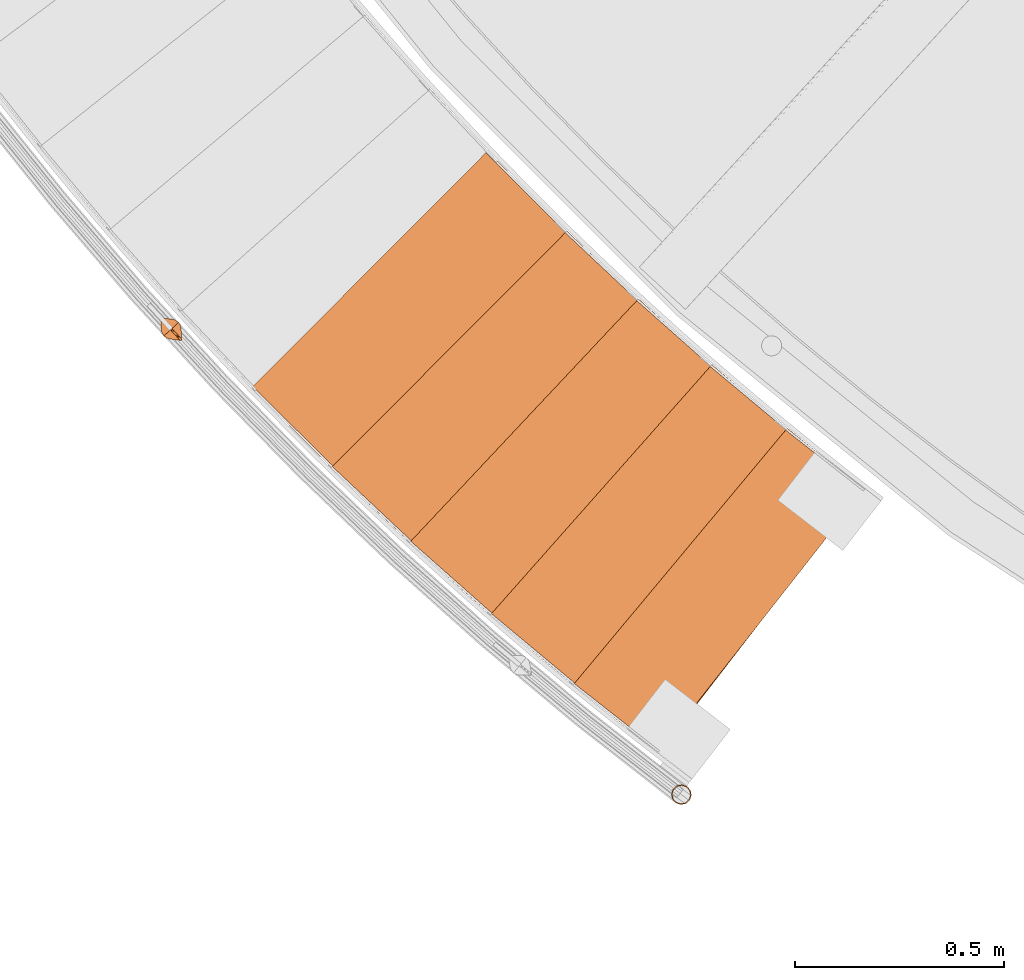
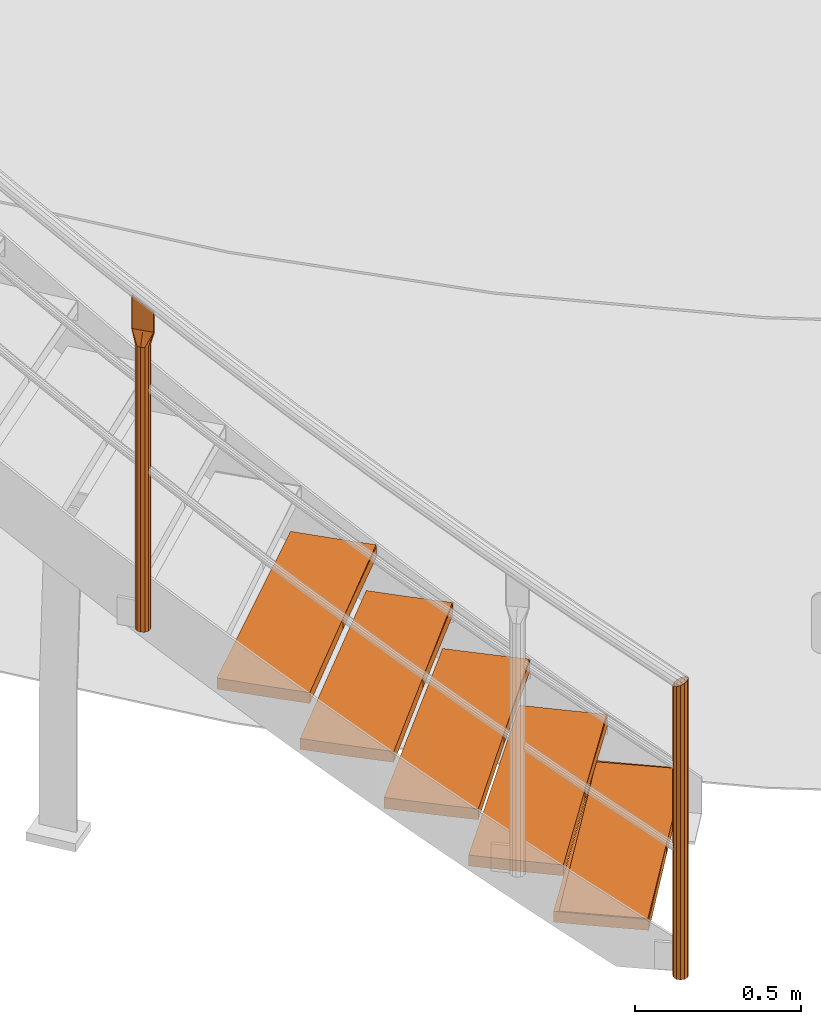
# One storey, part 1 of 126: 12 proxies.
"""IFC2X3 building model written with IfcOpenShell, lengths in millimetres."""

from ifc_helpers import new_model, si_unit, origin, origin_with_axes, place, context, project, spatial, faceted_brep, material, element, save


model = new_model("IFC2X3")

# Units and contexts
context_of_model_1 = context(None, 3, precision=0.1, world=origin())
context_of_model_2 = context(None, 3, precision=0.1, world=origin())
ifc_project = project(units=[si_unit("LENGTHUNIT", "METRE", prefix="MILLI"), si_unit("AREAUNIT", "SQUARE_METRE", prefix="CENTI"), si_unit("VOLUMEUNIT", "CUBIC_METRE", prefix="CENTI"), si_unit("MASSUNIT", "GRAM", prefix="KILO")], contexts=[context_of_model_1, context_of_model_2])

# Site, building, storey
site_placement = place(None, origin_with_axes())
site = spatial("IfcSite", under=ifc_project, at=site_placement, CompositionType="ELEMENT")
building_placement = place(site_placement, origin_with_axes())
building = spatial("IfcBuilding", under=site, at=building_placement, CompositionType="ELEMENT")
storey_placement = place(building_placement, origin_with_axes())
storey = spatial("IfcBuildingStorey", under=building, at=storey_placement, CompositionType="ELEMENT")

# Proxies
ifc_material_1 = material(Name="HOLZ")
proxy_1_placement = place(storey_placement, origin_with_axes())
element("IfcBuildingElementProxy", 1, at=proxy_1_placement, inside=storey, material=ifc_material_1, context=context_of_model_2, shape_type="Brep", body=[
    faceted_brep([(2392.9451, 1204.6817, 173.2062), (2413.2724, 1187.9574, 173.2062), (2433.6495, 1171.2937, 173.2062), (2454.0762, 1154.691, 173.2062), (2474.5524, 1138.1493, 173.2062), (2495.0779, 1121.6689, 173.2062), (2515.6526, 1105.2497, 173.2062), (2536.2761, 1088.8921, 173.2062), (2556.9484, 1072.5962, 173.2062), (2577.6693, 1056.362, 173.2062), (2598.4385, 1040.1897, 173.2062), (2619.2559, 1024.0796, 173.2062), (3107.9251, 1657.485, 173.2062), (3086.8911, 1673.7684, 173.2062), (3065.9113, 1690.1214, 173.2062), (3044.9858, 1706.544, 173.2062), (3024.1149, 1723.0359, 173.2062), (3003.2989, 1739.597, 173.2062), (2982.5379, 1756.2271, 173.2062), (2961.8322, 1772.9259, 173.2062), (2941.182, 1789.6934, 173.2062), (2920.5876, 1806.5293, 173.2062), (2900.0492, 1823.4334, 173.2062), (2392.9451, 1204.6817, 133.2062), (2900.0492, 1823.4334, 133.2062), (2920.5876, 1806.5293, 133.2062), (2941.182, 1789.6934, 133.2062), (2961.8322, 1772.9259, 133.2062), (2982.5379, 1756.2271, 133.2062), (3003.2989, 1739.597, 133.2062), (3024.1149, 1723.0359, 133.2062), (3044.9858, 1706.544, 133.2062), (3065.9113, 1690.1214, 133.2062), (3086.8911, 1673.7684, 133.2062), (3107.9251, 1657.485, 133.2062), (2619.2559, 1024.0796, 133.2062), (2598.4385, 1040.1897, 133.2062), (2577.6693, 1056.362, 133.2062), (2556.9484, 1072.5962, 133.2062), (2536.2761, 1088.8921, 133.2062), (2515.6526, 1105.2497, 133.2062), (2495.0779, 1121.6689, 133.2062), (2474.5524, 1138.1493, 133.2062), (2454.0762, 1154.691, 133.2062), (2433.6495, 1171.2937, 133.2062), (2413.2724, 1187.9574, 133.2062)], [[[0, 1, 2, 3, 4, 5, 6, 7, 8, 9, 10, 11, 12, 13, 14, 15, 16, 17, 18, 19, 20, 21, 22]], [[23, 24, 25, 26, 27, 28, 29, 30, 31, 32, 33, 34, 35, 36, 37, 38, 39, 40, 41, 42, 43, 44, 45]], [[0, 23, 45, 1]], [[1, 45, 44, 2]], [[2, 44, 43, 3]], [[3, 43, 42, 4]], [[4, 42, 41, 5]], [[5, 41, 40, 6]], [[6, 40, 39, 7]], [[7, 39, 38, 8]], [[8, 38, 37, 9]], [[9, 37, 36, 10]], [[10, 36, 35, 11]], [[11, 35, 34, 12]], [[12, 34, 33, 13]], [[13, 33, 32, 14]], [[14, 32, 31, 15]], [[15, 31, 30, 16]], [[16, 30, 29, 17]], [[17, 29, 28, 18]], [[18, 28, 27, 19]], [[19, 27, 26, 20]], [[20, 26, 25, 21]], [[21, 25, 24, 22]], [[22, 24, 23, 0]]]),
])
proxy_2_placement = place(storey_placement, origin_with_axes())
element("IfcBuildingElementProxy", 2, at=proxy_2_placement, inside=storey, material=ifc_material_1, context=context_of_model_2, shape_type="Brep", body=[
    faceted_brep([(2195.2187, 1372.8111, 346.4125), (2215.0449, 1355.4956, 346.4125), (2234.9227, 1338.2395, 346.4125), (2254.8519, 1321.0427, 346.4125), (2274.8324, 1303.9055, 346.4125), (2294.864, 1286.828, 346.4125), (2314.9464, 1269.8105, 346.4125), (2335.0796, 1252.8529, 346.4125), (2355.2632, 1235.9555, 346.4125), (2375.4973, 1219.1185, 346.4125), (2395.7815, 1202.3419, 346.4125), (2416.1158, 1185.626, 346.4125), (2923.2166, 1804.3738, 346.4125), (2902.671, 1821.2692, 346.4125), (2882.1815, 1838.2327, 346.4125), (2861.7485, 1855.264, 346.4125), (2841.3721, 1872.3631, 346.4125), (2821.0525, 1889.5297, 346.4125), (2800.79, 1906.7636, 346.4125), (2780.5848, 1924.0647, 346.4125), (2760.4371, 1941.4327, 346.4125), (2740.3472, 1958.8675, 346.4125), (2720.3152, 1976.3688, 346.4125), (2195.2187, 1372.8111, 306.4125), (2720.3152, 1976.3688, 306.4125), (2740.3472, 1958.8675, 306.4125), (2760.4371, 1941.4327, 306.4125), (2780.5848, 1924.0647, 306.4125), (2800.79, 1906.7636, 306.4125), (2821.0525, 1889.5297, 306.4125), (2841.3721, 1872.3631, 306.4125), (2861.7485, 1855.264, 306.4125), (2882.1815, 1838.2327, 306.4125), (2902.671, 1821.2692, 306.4125), (2923.2166, 1804.3738, 306.4125), (2416.1158, 1185.626, 306.4125), (2395.7815, 1202.3419, 306.4125), (2375.4973, 1219.1185, 306.4125), (2355.2632, 1235.9555, 306.4125), (2335.0796, 1252.8529, 306.4125), (2314.9464, 1269.8105, 306.4125), (2294.864, 1286.828, 306.4125), (2274.8324, 1303.9055, 306.4125), (2254.8519, 1321.0427, 306.4125), (2234.9227, 1338.2395, 306.4125), (2215.0449, 1355.4956, 306.4125)], [[[0, 1, 2, 3, 4, 5, 6, 7, 8, 9, 10, 11, 12, 13, 14, 15, 16, 17, 18, 19, 20, 21, 22]], [[23, 24, 25, 26, 27, 28, 29, 30, 31, 32, 33, 34, 35, 36, 37, 38, 39, 40, 41, 42, 43, 44, 45]], [[0, 23, 45, 1]], [[1, 45, 44, 2]], [[2, 44, 43, 3]], [[3, 43, 42, 4]], [[4, 42, 41, 5]], [[5, 41, 40, 6]], [[6, 40, 39, 7]], [[7, 39, 38, 8]], [[8, 38, 37, 9]], [[9, 37, 36, 10]], [[10, 36, 35, 11]], [[11, 35, 34, 12]], [[12, 34, 33, 13]], [[13, 33, 32, 14]], [[14, 32, 31, 15]], [[15, 31, 30, 16]], [[16, 30, 29, 17]], [[17, 29, 28, 18]], [[18, 28, 27, 19]], [[19, 27, 26, 20]], [[20, 26, 25, 21]], [[21, 25, 24, 22]], [[22, 24, 23, 0]]]),
])
proxy_3_placement = place(storey_placement, origin_with_axes())
element("IfcBuildingElementProxy", 3, at=proxy_3_placement, inside=storey, material=ifc_material_1, context=context_of_model_2, shape_type="Brep", body=[
    faceted_brep([(2002.5267, 1546.6874, 519.6187), (2021.8346, 1528.7959, 519.6187), (2041.1959, 1510.9621, 519.6187), (2060.6103, 1493.1862, 519.6187), (2080.0777, 1475.4683, 519.6187), (2099.5979, 1457.8087, 519.6187), (2119.1708, 1440.2074, 519.6187), (2138.7961, 1422.6646, 519.6187), (2158.4737, 1405.1804, 519.6187), (2178.2034, 1387.7551, 519.6187), (2197.9851, 1370.3888, 519.6187), (2217.8185, 1353.0816, 519.6187), (2742.9116, 1956.6355, 519.6187), (2722.8721, 1974.1283, 519.6187), (2702.8909, 1991.6875, 519.6187), (2682.968, 2009.313, 519.6187), (2663.1037, 2027.0044, 519.6187), (2643.2982, 2044.7616, 519.6187), (2623.5517, 2062.5845, 519.6187), (2603.8645, 2080.4727, 519.6187), (2584.2368, 2098.4262, 519.6187), (2564.6687, 2116.4448, 519.6187), (2545.1605, 2134.5281, 519.6187), (2002.5267, 1546.6874, 479.6187), (2545.1605, 2134.5281, 479.6187), (2564.6687, 2116.4448, 479.6187), (2584.2368, 2098.4262, 479.6187), (2603.8645, 2080.4727, 479.6187), (2623.5517, 2062.5845, 479.6187), (2643.2982, 2044.7616, 479.6187), (2663.1037, 2027.0044, 479.6187), (2682.968, 2009.313, 479.6187), (2702.8909, 1991.6875, 479.6187), (2722.8721, 1974.1283, 479.6187), (2742.9116, 1956.6355, 479.6187), (2217.8185, 1353.0816, 479.6187), (2197.9851, 1370.3888, 479.6187), (2178.2034, 1387.7551, 479.6187), (2158.4737, 1405.1804, 479.6187), (2138.7961, 1422.6646, 479.6187), (2119.1708, 1440.2074, 479.6187), (2099.5979, 1457.8087, 479.6187), (2080.0777, 1475.4683, 479.6187), (2060.6103, 1493.1862, 479.6187), (2041.1959, 1510.9621, 479.6187), (2021.8346, 1528.7959, 479.6187)], [[[0, 1, 2, 3, 4, 5, 6, 7, 8, 9, 10, 11, 12, 13, 14, 15, 16, 17, 18, 19, 20, 21, 22]], [[23, 24, 25, 26, 27, 28, 29, 30, 31, 32, 33, 34, 35, 36, 37, 38, 39, 40, 41, 42, 43, 44, 45]], [[0, 23, 45, 1]], [[1, 45, 44, 2]], [[2, 44, 43, 3]], [[3, 43, 42, 4]], [[4, 42, 41, 5]], [[5, 41, 40, 6]], [[6, 40, 39, 7]], [[7, 39, 38, 8]], [[8, 38, 37, 9]], [[9, 37, 36, 10]], [[10, 36, 35, 11]], [[11, 35, 34, 12]], [[12, 34, 33, 13]], [[13, 33, 32, 14]], [[14, 32, 31, 15]], [[15, 31, 30, 16]], [[16, 30, 29, 17]], [[17, 29, 28, 18]], [[18, 28, 27, 19]], [[19, 27, 26, 20]], [[20, 26, 25, 21]], [[21, 25, 24, 22]], [[22, 24, 23, 0]]]),
])
proxy_4_placement = place(storey_placement, origin_with_axes())
element("IfcBuildingElementProxy", 4, at=proxy_4_placement, inside=storey, material=ifc_material_1, context=context_of_model_2, shape_type="Brep", body=[
    faceted_brep([(1815.0359, 1726.16, 692.825), (1833.8089, 1707.7079, 692.825), (1852.6368, 1689.312, 692.825), (1871.5196, 1670.9724, 692.825), (1890.4571, 1652.6892, 692.825), (1909.4491, 1634.4626, 692.825), (1928.4954, 1616.2928, 692.825), (1947.5959, 1598.18, 692.825), (1966.7503, 1580.1243, 692.825), (1985.9586, 1562.1258, 692.825), (2005.2205, 1544.1848, 692.825), (2024.5359, 1526.3013, 692.825), (2567.1662, 2114.1383, 692.825), (2547.6504, 2132.2134, 692.825), (2528.1946, 2150.3531, 692.825), (2508.7991, 2168.5573, 692.825), (2489.4642, 2186.8257, 692.825), (2470.1899, 2205.1582, 692.825), (2450.9766, 2223.5545, 692.825), (2431.8244, 2242.0145, 692.825), (2412.7336, 2260.538, 692.825), (2393.7044, 2279.1246, 692.825), (2374.7369, 2297.7744, 692.825), (1815.0359, 1726.16, 652.825), (2374.7369, 2297.7744, 652.825), (2393.7044, 2279.1246, 652.825), (2412.7336, 2260.538, 652.825), (2431.8244, 2242.0145, 652.825), (2450.9766, 2223.5545, 652.825), (2470.1899, 2205.1582, 652.825), (2489.4642, 2186.8257, 652.825), (2508.7991, 2168.5573, 652.825), (2528.1946, 2150.3531, 652.825), (2547.6504, 2132.2134, 652.825), (2567.1662, 2114.1383, 652.825), (2024.5359, 1526.3013, 652.825), (2005.2205, 1544.1848, 652.825), (1985.9586, 1562.1258, 652.825), (1966.7503, 1580.1243, 652.825), (1947.5959, 1598.18, 652.825), (1928.4954, 1616.2928, 652.825), (1909.4491, 1634.4626, 652.825), (1890.4571, 1652.6892, 652.825), (1871.5196, 1670.9724, 652.825), (1852.6368, 1689.312, 652.825), (1833.8089, 1707.7079, 652.825)], [[[0, 1, 2, 3, 4, 5, 6, 7, 8, 9, 10, 11, 12, 13, 14, 15, 16, 17, 18, 19, 20, 21, 22]], [[23, 24, 25, 26, 27, 28, 29, 30, 31, 32, 33, 34, 35, 36, 37, 38, 39, 40, 41, 42, 43, 44, 45]], [[0, 23, 45, 1]], [[1, 45, 44, 2]], [[2, 44, 43, 3]], [[3, 43, 42, 4]], [[4, 42, 41, 5]], [[5, 41, 40, 6]], [[6, 40, 39, 7]], [[7, 39, 38, 8]], [[8, 38, 37, 9]], [[9, 37, 36, 10]], [[10, 36, 35, 11]], [[11, 35, 34, 12]], [[12, 34, 33, 13]], [[13, 33, 32, 14]], [[14, 32, 31, 15]], [[15, 31, 30, 16]], [[16, 30, 29, 17]], [[17, 29, 28, 18]], [[18, 28, 27, 19]], [[19, 27, 26, 20]], [[20, 26, 25, 21]], [[21, 25, 24, 22]], [[22, 24, 23, 0]]]),
])
proxy_5_placement = place(storey_placement, origin_with_axes())
element("IfcBuildingElementProxy", 5, at=proxy_5_placement, inside=storey, material=ifc_material_1, context=context_of_model_2, shape_type="Brep", body=[
    faceted_brep([(1632.9089, 1911.0733, 866.0312), (1651.1306, 1892.0767, 866.0312), (1669.409, 1873.1346, 866.0312), (1687.7438, 1854.2471, 866.0312), (1706.1349, 1835.4145, 866.0312), (1724.5822, 1816.6368, 866.0312), (1743.0854, 1797.9143, 866.0312), (1761.6445, 1779.2471, 866.0312), (1780.2592, 1760.6354, 866.0312), (1798.9294, 1742.0794, 866.0312), (1817.6549, 1723.5791, 866.0312), (1836.4356, 1705.1349, 866.0312), (2396.133, 2276.7456, 866.0312), (2377.1576, 2295.3873, 866.0312), (2358.2441, 2314.0918, 866.0312), (2339.3929, 2332.859, 866.0312), (2320.604, 2351.6886, 866.0312), (2301.8777, 2370.5805, 866.0312), (2283.2142, 2389.5344, 866.0312), (2264.6136, 2408.5501, 866.0312), (2246.0763, 2427.6274, 866.0312), (2227.6024, 2446.7661, 866.0312), (2209.192, 2465.966, 866.0312), (1632.9089, 1911.0733, 826.0312), (2209.192, 2465.966, 826.0312), (2227.6024, 2446.7661, 826.0312), (2246.0763, 2427.6274, 826.0312), (2264.6136, 2408.5501, 826.0312), (2283.2142, 2389.5344, 826.0312), (2301.8777, 2370.5805, 826.0312), (2320.604, 2351.6886, 826.0312), (2339.3929, 2332.859, 826.0312), (2358.2441, 2314.0918, 826.0312), (2377.1576, 2295.3873, 826.0312), (2396.133, 2276.7456, 826.0312), (1836.4356, 1705.1349, 826.0312), (1817.6549, 1723.5791, 826.0312), (1798.9294, 1742.0794, 826.0312), (1780.2592, 1760.6354, 826.0312), (1761.6445, 1779.2471, 826.0312), (1743.0854, 1797.9143, 826.0312), (1724.5822, 1816.6368, 826.0312), (1706.1349, 1835.4145, 826.0312), (1687.7438, 1854.2471, 826.0312), (1669.409, 1873.1346, 826.0312), (1651.1306, 1892.0767, 826.0312)], [[[0, 1, 2, 3, 4, 5, 6, 7, 8, 9, 10, 11, 12, 13, 14, 15, 16, 17, 18, 19, 20, 21, 22]], [[23, 24, 25, 26, 27, 28, 29, 30, 31, 32, 33, 34, 35, 36, 37, 38, 39, 40, 41, 42, 43, 44, 45]], [[0, 23, 45, 1]], [[1, 45, 44, 2]], [[2, 44, 43, 3]], [[3, 43, 42, 4]], [[4, 42, 41, 5]], [[5, 41, 40, 6]], [[6, 40, 39, 7]], [[7, 39, 38, 8]], [[8, 38, 37, 9]], [[9, 37, 36, 10]], [[10, 36, 35, 11]], [[11, 35, 34, 12]], [[12, 34, 33, 13]], [[13, 33, 32, 14]], [[14, 32, 31, 15]], [[15, 31, 30, 16]], [[16, 30, 29, 17]], [[17, 29, 28, 18]], [[18, 28, 27, 19]], [[19, 27, 26, 20]], [[20, 26, 25, 21]], [[21, 25, 24, 22]], [[22, 24, 23, 0]]]),
])
ifc_material_2 = material(Name="S235JRG2")
proxy_6_placement = place(storey_placement, origin_with_axes())
element("IfcBuildingElementProxy", 6, at=proxy_6_placement, inside=storey, material=ifc_material_2, context=context_of_model_2, shape_type="Brep", body=[
    faceted_brep([(2619.5904, 1030.1555, 133.21), (2619.5904, 1030.1555, 173.21), (2407.2634, 1196.9405, 173.21), (2407.2634, 1196.9405, 133.21), (3107.5909, 1651.4086, 133.21), (2895.2639, 1818.1936, 133.21), (2895.2639, 1818.1936, 173.21), (3107.5909, 1651.4086, 173.21)], [[[0, 1, 2, 3]], [[4, 5, 6, 7]], [[0, 4, 7, 1]], [[1, 7, 6, 2]], [[2, 6, 5, 3]], [[3, 5, 4, 0]]]),
])
proxy_7_placement = place(storey_placement, origin_with_axes())
element("IfcBuildingElementProxy", 7, at=proxy_7_placement, inside=storey, material=ifc_material_2, context=context_of_model_2, shape_type="Brep", body=[
    faceted_brep([(2416.6294, 1191.689, 306.37), (2416.6294, 1191.689, 346.37), (2209.3035, 1364.6512, 346.37), (2209.3035, 1364.6512, 306.37), (2922.7042, 1798.3094, 306.37), (2715.3783, 1971.2716, 306.37), (2715.3783, 1971.2716, 346.37), (2922.7042, 1798.3094, 346.37)], [[[0, 1, 2, 3]], [[4, 5, 6, 7]], [[0, 4, 7, 1]], [[1, 7, 6, 2]], [[2, 6, 5, 3]], [[3, 5, 4, 0]]]),
])
proxy_8_placement = place(storey_placement, origin_with_axes())
element("IfcBuildingElementProxy", 8, at=proxy_8_placement, inside=storey, material=ifc_material_2, context=context_of_model_2, shape_type="Brep", body=[
    faceted_brep([(2218.5109, 1359.1263, 479.53), (2218.5109, 1359.1263, 519.53), (2016.3657, 1538.116, 519.53), (2016.3657, 1538.116, 479.53), (2742.2214, 1950.5883, 479.53), (2540.0762, 2129.578, 479.53), (2540.0762, 2129.578, 519.53), (2742.2214, 1950.5883, 519.53)], [[[0, 1, 2, 3]], [[4, 5, 6, 7]], [[0, 4, 7, 1]], [[1, 7, 6, 2]], [[2, 6, 5, 3]], [[3, 5, 4, 0]]]),
])
proxy_9_placement = place(storey_placement, origin_with_axes())
element("IfcBuildingElementProxy", 9, at=proxy_9_placement, inside=storey, material=ifc_material_2, context=context_of_model_2, shape_type="Brep", body=[
    faceted_brep([(2025.4065, 1532.3224, 652.69), (2025.4065, 1532.3224, 692.69), (1828.6172, 1717.1844, 692.69), (1828.6172, 1717.1844, 652.69), (2566.2989, 2108.1136, 652.69), (2369.5096, 2292.9755, 652.69), (2369.5096, 2292.9755, 692.69), (2566.2989, 2108.1136, 692.69)], [[[0, 1, 2, 3]], [[4, 5, 6, 7]], [[0, 4, 7, 1]], [[1, 7, 6, 2]], [[2, 6, 5, 3]], [[3, 5, 4, 0]]]),
])
proxy_10_placement = place(storey_placement, origin_with_axes())
element("IfcBuildingElementProxy", 10, at=proxy_10_placement, inside=storey, material=ifc_material_2, context=context_of_model_2, shape_type="Brep", body=[
    faceted_brep([(1837.4836, 1711.1273, 825.85), (1837.4836, 1711.1273, 865.85), (1646.2206, 1901.7013, 865.85), (1646.2206, 1901.7013, 825.85), (2395.0892, 2270.7485, 825.85), (2203.8262, 2461.3226, 825.85), (2203.8262, 2461.3226, 865.85), (2395.0892, 2270.7485, 865.85)], [[[0, 1, 2, 3]], [[4, 5, 6, 7]], [[0, 4, 7, 1]], [[1, 7, 6, 2]], [[2, 6, 5, 3]], [[3, 5, 4, 0]]]),
])
proxy_11_placement = place(storey_placement, origin_with_axes())
element("IfcBuildingElementProxy", 11, at=proxy_11_placement, inside=storey, material=ifc_material_2, Name="HANDLAUF", context=context_of_model_2, shape_type="Brep", body=[
    faceted_brep([(2660.7548, 946.0525, 9.95), (2651.5854, 937.5556, 9.95), (2651.5854, 937.5556, 1075.2221), (2660.7548, 946.0525, 1076.2675), (2672.9441, 948.8263, 1080.4106), (2672.9441, 948.8263, 9.95), (2684.8873, 945.1338, 1086.5414), (2684.8873, 945.1338, 9.95), (2693.3842, 935.9645, 1093.0172), (2693.3842, 935.9645, 9.95), (2696.158, 923.7751, 1098.1026), (2696.158, 923.7751, 9.95), (2692.4655, 911.832, 1100.4352), (2692.4655, 911.832, 9.95), (2683.2962, 903.3351, 1099.3898), (2683.2962, 903.3351, 9.95), (2671.1068, 900.5613, 1095.2467), (2671.1068, 900.5613, 9.95), (2659.1636, 904.2537, 1089.1158), (2659.1636, 904.2537, 9.95), (2650.6668, 913.4231, 1082.6401), (2650.6668, 913.4231, 9.95), (2647.893, 925.6124, 1077.5547), (2647.893, 925.6124, 9.95), (2650.3911, 925.5173, 9.95), (2653.7014, 936.2242, 9.95), (2653.7014, 936.2242, 1076.5271), (2650.3911, 925.5173, 1078.6182), (2652.8778, 914.5898, 1083.1772), (2652.8778, 914.5898, 9.95), (2660.4951, 906.3697, 1088.9826), (2660.4951, 906.3697, 9.95), (2671.2019, 903.0595, 1094.4787), (2671.2019, 903.0595, 9.95), (2682.1294, 905.5461, 1098.193), (2682.1294, 905.5461, 9.95), (2690.3496, 913.1634, 1099.1301), (2690.3496, 913.1634, 9.95), (2693.6598, 923.8702, 1097.0391), (2693.6598, 923.8702, 9.95), (2691.1731, 934.7977, 1092.48), (2691.1731, 934.7977, 9.95), (2683.5558, 943.0179, 1086.6747), (2683.5558, 943.0179, 9.95), (2672.849, 946.3281, 1081.1785), (2672.849, 946.3281, 9.95), (2661.9215, 943.8414, 1077.4643), (2661.9215, 943.8414, 9.95)], [[[0, 1, 2, 3]], [[0, 3, 4, 5]], [[4, 6, 7, 5]], [[6, 8, 9, 7]], [[8, 10, 11, 9]], [[10, 12, 13, 11]], [[12, 14, 15, 13]], [[14, 16, 17, 15]], [[16, 18, 19, 17]], [[18, 20, 21, 19]], [[20, 22, 23, 21]], [[1, 23, 22, 2]], [[24, 25, 26, 27]], [[24, 27, 28, 29]], [[28, 30, 31, 29]], [[30, 32, 33, 31]], [[32, 34, 35, 33]], [[34, 36, 37, 35]], [[36, 38, 39, 37]], [[38, 40, 41, 39]], [[40, 42, 43, 41]], [[42, 44, 45, 43]], [[44, 46, 47, 45]], [[25, 47, 46, 26]], [[17, 19, 21, 23, 1, 0, 5, 7, 9, 11, 13, 15], [24, 29, 31, 33, 35, 37, 39, 41, 43, 45, 47, 25]], [[18, 16, 14, 12, 10, 8, 6, 4, 3, 2, 22, 20], [26, 46, 44, 42, 40, 38, 36, 34, 32, 30, 28, 27]]]),
])
ifc_material_3 = material(Name="1.4462")
proxy_12_placement = place(storey_placement, origin_with_axes())
element("IfcBuildingElementProxy", 12, at=proxy_12_placement, inside=storey, material=ifc_material_3, Name="Pfosten", context=context_of_model_2, shape_type="Brep", body=[
    faceted_brep([(1467.1861, 2021.1903, 2080.2008), (1456.1034, 2015.4071, 2080.2008), (1456.1034, 2015.4071, 1036.3446), (1467.1861, 2021.1903, 1036.3436), (1443.6138, 2015.94, 2080.2008), (1443.6138, 2015.94, 1036.3472), (1433.0639, 2022.6463, 2080.2008), (1433.0639, 2022.6463, 1036.3508), (1427.2807, 2033.7291, 2080.2008), (1427.2807, 2033.7291, 1036.3545), (1427.8136, 2046.2187, 2080.2008), (1427.8136, 2046.2187, 1036.3571), (1434.5199, 2056.7685, 2080.2008), (1434.5199, 2056.7685, 1036.3581), (1445.6027, 2062.5518, 2080.2008), (1445.6027, 2062.5518, 1036.3571), (1458.0923, 2062.0189, 2080.2008), (1458.0923, 2062.0189, 1036.3545), (1468.6421, 2055.3125, 2080.2008), (1468.6421, 2055.3125, 1036.3508), (1474.4254, 2044.2298, 2080.2008), (1474.4254, 2044.2298, 1036.3472), (1473.8925, 2031.7402, 2080.2008), (1473.8925, 2031.7402, 1036.3446), (1457.3429, 2059.6338, 2080.2008), (1446.1462, 2060.1116, 2080.2008), (1446.1462, 2060.1116, 1036.3565), (1457.3429, 2059.6338, 1036.3541), (1436.2107, 2054.927, 2080.2008), (1436.2107, 2054.927, 1036.3573), (1430.1986, 2045.4693, 2080.2008), (1430.1986, 2045.4693, 1036.3565), (1429.7209, 2034.2726, 2080.2008), (1429.7209, 2034.2726, 1036.3541), (1434.9055, 2024.3371, 2080.2008), (1434.9055, 2024.3371, 1036.3508), (1444.3632, 2018.325, 2080.2008), (1444.3632, 2018.325, 1036.3476), (1455.5599, 2017.8473, 2080.2008), (1455.5599, 2017.8473, 1036.3452), (1465.4953, 2023.0319, 2080.2008), (1465.4953, 2023.0319, 1036.3443), (1471.5074, 2032.4896, 2080.2008), (1471.5074, 2032.4896, 1036.3452), (1471.9852, 2043.6863, 2080.2008), (1471.9852, 2043.6863, 1036.3476), (1466.8006, 2053.6217, 2080.2008), (1466.8006, 2053.6217, 1036.3508), (1475.5439, 2012.0875, 2128.5008), (1473.7465, 2011.4313, 2128.5008), (1472.0116, 2012.2382, 2128.5008), (1449.0115, 2037.2886, 2128.5008), (1426.0114, 2062.339, 2128.5008), (1425.3552, 2064.1364, 2128.5008), (1426.1621, 2065.8714, 2128.5008), (1427.9595, 2066.5276, 2128.5008), (1429.6945, 2065.7206, 2128.5008), (1452.6946, 2040.6702, 2128.5008), (1475.6946, 2015.6198, 2128.5008), (1476.3508, 2013.8225, 2128.5008), (1428.0003, 2064.1651, 2128.5008), (1427.8615, 2064.2296, 2128.5008), (1427.7177, 2064.1772, 2128.5008), (1427.6531, 2064.0384, 2128.5008), (1427.7056, 2063.8946, 2128.5008), (1450.7057, 2038.8442, 2128.5008), (1473.7058, 2013.7938, 2128.5008), (1473.8446, 2013.7292, 2128.5008), (1473.9884, 2013.7817, 2128.5008), (1474.0529, 2013.9205, 2128.5008), (1474.0004, 2014.0643, 2128.5008), (1451.0004, 2039.1147, 2128.5008), (1475.5439, 2012.0875, 2199.7625), (1473.7465, 2011.4313, 2200.2779), (1472.0116, 2012.2382, 2201.5221), (1449.0115, 2037.2886, 2225.4574), (1426.0114, 2062.339, 2249.3927), (1425.3552, 2064.1364, 2250.6369), (1426.1621, 2065.8714, 2251.1523), (1427.9595, 2066.5276, 2250.6369), (1429.6945, 2065.7206, 2249.3927), (1452.6946, 2040.6702, 2225.4574), (1475.6946, 2015.6198, 2201.5221), (1476.3508, 2013.8225, 2200.2779), (1428.0003, 2064.1651, 2249.3927), (1427.8615, 2064.2296, 2249.4922), (1427.7177, 2064.1772, 2249.5335), (1427.6531, 2064.0384, 2249.4922), (1427.7056, 2063.8946, 2249.3927), (1450.7057, 2038.8442, 2225.4574), (1473.7058, 2013.7938, 2201.5221), (1473.8446, 2013.7292, 2201.4225), (1473.9884, 2013.7817, 2201.3813), (1474.0529, 2013.9205, 2201.4225), (1474.0004, 2014.0643, 2201.5221), (1451.0004, 2039.1147, 2225.4574)], [[[0, 1, 2, 3]], [[1, 4, 5, 2]], [[4, 6, 7, 5]], [[6, 8, 9, 7]], [[8, 10, 11, 9]], [[10, 12, 13, 11]], [[12, 14, 15, 13]], [[14, 16, 17, 15]], [[16, 18, 19, 17]], [[18, 20, 21, 19]], [[20, 22, 23, 21]], [[0, 3, 23, 22]], [[24, 25, 26, 27]], [[25, 28, 29, 26]], [[28, 30, 31, 29]], [[30, 32, 33, 31]], [[32, 34, 35, 33]], [[34, 36, 37, 35]], [[36, 38, 39, 37]], [[38, 40, 41, 39]], [[40, 42, 43, 41]], [[42, 44, 45, 43]], [[44, 46, 47, 45]], [[24, 27, 47, 46]], [[0, 48, 49, 1]], [[1, 49, 50, 4]], [[4, 50, 51, 6]], [[6, 51, 52, 8]], [[8, 52, 53, 10]], [[10, 53, 54, 12]], [[12, 54, 55, 14]], [[14, 55, 56, 16]], [[16, 56, 57, 18]], [[18, 57, 58, 20]], [[20, 58, 59, 22]], [[22, 59, 48, 0]], [[24, 60, 61, 25]], [[25, 61, 62, 28]], [[28, 62, 63, 30]], [[30, 63, 64, 32]], [[32, 64, 65, 34]], [[34, 65, 66, 36]], [[36, 66, 67, 38]], [[38, 67, 68, 40]], [[40, 68, 69, 42]], [[42, 69, 70, 44]], [[44, 70, 71, 46]], [[46, 71, 60, 24]], [[48, 72, 73, 49]], [[49, 73, 74, 50]], [[50, 74, 75, 51]], [[51, 75, 76, 52]], [[52, 76, 77, 53]], [[53, 77, 78, 54]], [[54, 78, 79, 55]], [[55, 79, 80, 56]], [[56, 80, 81, 57]], [[57, 81, 82, 58]], [[58, 82, 83, 59]], [[48, 59, 83, 72]], [[60, 84, 85, 61]], [[61, 85, 86, 62]], [[62, 86, 87, 63]], [[63, 87, 88, 64]], [[64, 88, 89, 65]], [[65, 89, 90, 66]], [[66, 90, 91, 67]], [[67, 91, 92, 68]], [[68, 92, 93, 69]], [[69, 93, 94, 70]], [[70, 94, 95, 71]], [[60, 71, 95, 84]], [[7, 9, 11, 13, 15, 17, 19, 21, 23, 3, 2, 5], [26, 29, 31, 33, 35, 37, 39, 41, 43, 45, 47, 27]], [[74, 73, 72, 83, 82, 81, 80, 79, 78, 77, 76, 75], [84, 95, 94, 93, 92, 91, 90, 89, 88, 87, 86, 85]]]),
])

save(model, "model.ifc")
